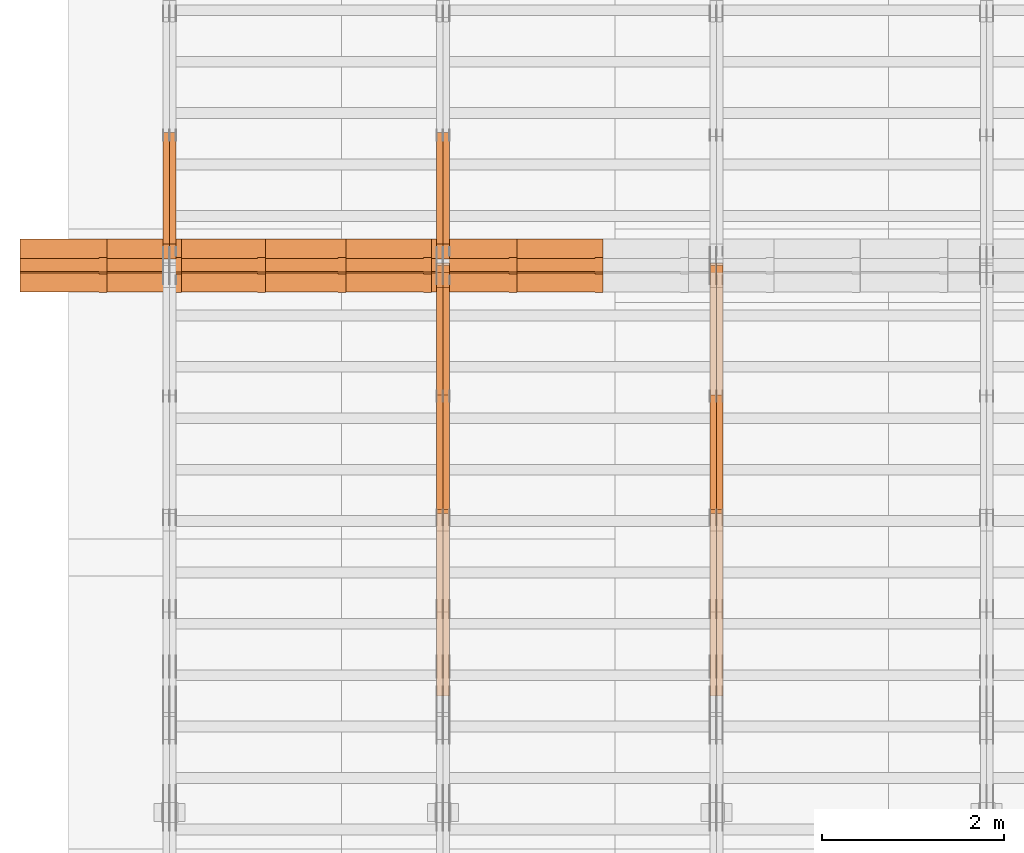
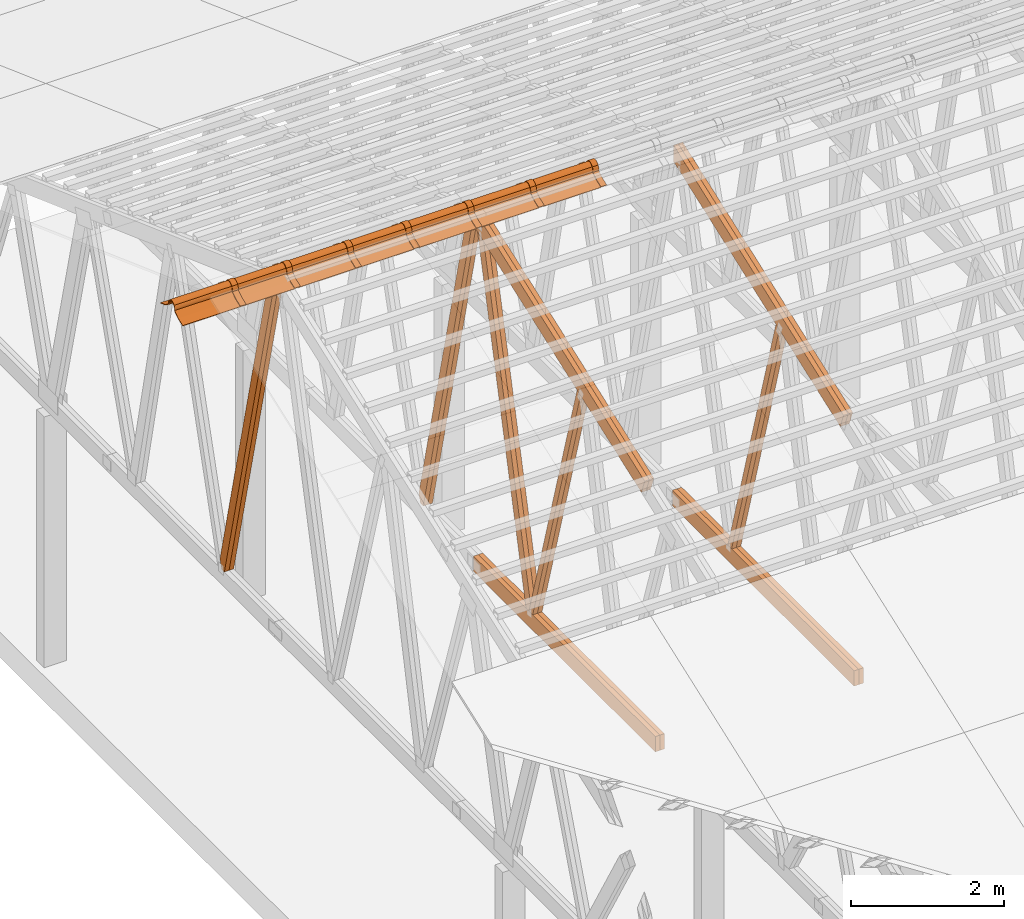
# One storey, part 17 of 189: 32 proxies.
"""IFC2X3 building model written with IfcOpenShell, lengths in millimetres."""

from ifc_helpers import new_model, entity, si_unit, converted_unit, derived_unit, direction, frame, frame_2d, origin, origin_2d_with_axis, place, context, subcontext, project, spatial, polyline, circle_curve, parameter, trimmed, segment, composite_curve, rectangle, outline, extrude, source, transform, mapped, material, type_object, type_shapes, element, save


model = new_model("IFC2X3")

# Units and contexts
model_context = context("Model", 3, precision=0.01, world=origin(), true_north=direction((6.12303176911189e-17, 1.0)))
body_context = subcontext(model_context, "Body", "Model", "MODEL_VIEW")
ifc_project = project(units=[si_unit("LENGTHUNIT", "METRE", prefix="MILLI"), si_unit("AREAUNIT", "SQUARE_METRE"), si_unit("VOLUMEUNIT", "CUBIC_METRE"), converted_unit("PLANEANGLEUNIT", "DEGREE", entity("IfcRatioMeasure", 0.0174532925199433), si_unit("PLANEANGLEUNIT", "RADIAN"), dimensions=[0, 0, 0, 0, 0, 0, 0]), si_unit("MASSUNIT", "GRAM", prefix="KILO"), derived_unit("MASSDENSITYUNIT", [(si_unit("MASSUNIT", "GRAM", prefix="KILO"), 1), (si_unit("LENGTHUNIT", "METRE"), -3)]), si_unit("TIMEUNIT", "SECOND"), si_unit("FREQUENCYUNIT", "HERTZ"), si_unit("THERMODYNAMICTEMPERATUREUNIT", "DEGREE_CELSIUS"), derived_unit("THERMALTRANSMITTANCEUNIT", [(si_unit("MASSUNIT", "GRAM", prefix="KILO"), 1), (si_unit("THERMODYNAMICTEMPERATUREUNIT", "KELVIN"), -1), (si_unit("TIMEUNIT", "SECOND"), -3)]), derived_unit("VOLUMETRICFLOWRATEUNIT", [(si_unit("LENGTHUNIT", "METRE"), 3), (si_unit("TIMEUNIT", "SECOND"), -1)]), si_unit("ELECTRICCURRENTUNIT", "AMPERE"), si_unit("ELECTRICVOLTAGEUNIT", "VOLT"), si_unit("POWERUNIT", "WATT"), si_unit("FORCEUNIT", "NEWTON"), si_unit("ILLUMINANCEUNIT", "LUX"), si_unit("LUMINOUSFLUXUNIT", "LUMEN"), si_unit("LUMINOUSINTENSITYUNIT", "CANDELA"), derived_unit("USERDEFINED", [(si_unit("MASSUNIT", "GRAM", prefix="KILO"), -1), (si_unit("LENGTHUNIT", "METRE"), -2), (si_unit("TIMEUNIT", "SECOND"), 3), (si_unit("LUMINOUSFLUXUNIT", "LUMEN"), 1)]), derived_unit("LINEARVELOCITYUNIT", [(si_unit("LENGTHUNIT", "METRE"), 1), (si_unit("TIMEUNIT", "SECOND"), -1)]), si_unit("PRESSUREUNIT", "PASCAL"), derived_unit("USERDEFINED", [(si_unit("LENGTHUNIT", "METRE"), -2), (si_unit("MASSUNIT", "GRAM", prefix="KILO"), 1), (si_unit("TIMEUNIT", "SECOND"), -2)])], contexts=[model_context])

# Site, building, storey
site_placement = place(None, origin())
site = spatial("IfcSite", under=ifc_project, at=site_placement, CompositionType="ELEMENT")
building_placement = place(site_placement, origin())
building = spatial("IfcBuilding", under=site, at=building_placement, CompositionType="ELEMENT")
storey_placement = place(building_placement, origin())
storey = spatial("IfcBuildingStorey", under=building, at=storey_placement, Name="Default", CompositionType="ELEMENT", Elevation=0.0)

# Proxies
ifc_material_1 = material(Name="IfcSurfaceStyle #36790")
building_element_proxy_type_1 = type_object("IfcBuildingElementProxyType", Name="T1-W6 36788", PredefinedType="NOTDEFINED", material=ifc_material_1)
shared_shape_1 = source(origin(), body_context, "Body", "SweptSolid", [
    extrude(outline(polyline([(-2640.84340836012, -47.4996765865792), (1711.12245024294, -47.4996765865792), (1797.68490303083, -9.57690019346202e-05), (1800.72595169379, 47.4997244710801), (-2668.68989660745, 47.4997244710801), (-2640.84340836012, -47.4996765865792)])), frame((1800.72595169379, 47.5003009358159, 0.0), z_axis=(0.0, 0.0, 1.0), x_axis=(-1.0, 0.0, 0.0)), (0.0, 0.0, 1.0), 69.9999999999997),
])
type_shapes(building_element_proxy_type_1, [shared_shape_1])
proxy_1_placement = place(building_placement, frame((6335.0, 12074.2896156894, 4533.9586582452), z_axis=(-1.0, 0.0, 0.0), x_axis=(0.0, 0.28128598310461, -0.959623986626467)))
element("IfcBuildingElementProxy", 1, at=proxy_1_placement, inside=storey, type_object=building_element_proxy_type_1, material=ifc_material_1, Name="T1-W6", context=body_context, shape_type="MappedRepresentation", body=[
    mapped(shared_shape_1, transform((0.0, 0.0, 0.0), scale=1.0)),
])
ifc_material_2 = material(Name="IfcSurfaceStyle #36724")
building_element_proxy_type_2 = type_object("IfcBuildingElementProxyType", Name="T1-W6 36722", PredefinedType="NOTDEFINED", material=ifc_material_2)
shared_shape_2 = source(origin(), body_context, "Body", "SweptSolid", [
    extrude(outline(polyline([(-2640.84340836012, -47.4996765865792), (1711.12245024294, -47.4996765865792), (1797.68490303083, -9.57690019346202e-05), (1800.72595169379, 47.4997244710801), (-2668.68989660745, 47.4997244710801), (-2640.84340836012, -47.4996765865792)])), frame((1800.72595169379, 47.5003009358159, 0.0), z_axis=(0.0, 0.0, 1.0), x_axis=(-1.0, 0.0, 0.0)), (0.0, 0.0, 1.0), 69.9999999999997),
])
type_shapes(building_element_proxy_type_2, [shared_shape_2])
proxy_2_placement = place(building_placement, frame((6265.0, 12074.2896156894, 4533.9586582452), z_axis=(-1.0, 0.0, 0.0), x_axis=(0.0, 0.28128598310461, -0.959623986626467)))
element("IfcBuildingElementProxy", 2, at=proxy_2_placement, inside=storey, type_object=building_element_proxy_type_2, material=ifc_material_2, Name="T1-W6", context=body_context, shape_type="MappedRepresentation", body=[
    mapped(shared_shape_2, transform((0.0, 0.0, 0.0), scale=1.0)),
])
ifc_material_3 = material(Name="IfcSurfaceStyle #32770")
building_element_proxy_type_3 = type_object("IfcBuildingElementProxyType", Name="T1-B3 32768", PredefinedType="NOTDEFINED", material=ifc_material_3)
shared_shape_3 = source(origin(), body_context, "Body", "SweptSolid", [
    extrude(rectangle(XDim=4751.0283203125, YDim=245.000000000001, at=origin_2d_with_axis()), frame((2375.51416015625, 122.5, 0.0), z_axis=(0.0, 0.0, 1.0), x_axis=(-1.0, 0.0, 0.0)), (0.0, 0.0, 1.0), 69.9999999999997),
])
type_shapes(building_element_proxy_type_3, [shared_shape_3])
proxy_3_placement = place(building_placement, frame((6335.0, 10029.23046875, 245.0), z_axis=(-1.0, 0.0, 0.0), x_axis=(0.0, 1.0, 0.0)))
element("IfcBuildingElementProxy", 3, at=proxy_3_placement, inside=storey, type_object=building_element_proxy_type_3, material=ifc_material_3, Name="T1-B3", context=body_context, shape_type="MappedRepresentation", body=[
    mapped(shared_shape_3, transform((0.0, 0.0, 0.0), scale=1.0)),
])
ifc_material_4 = material(Name="IfcSurfaceStyle #32713")
building_element_proxy_type_4 = type_object("IfcBuildingElementProxyType", Name="T1-B3 32711", PredefinedType="NOTDEFINED", material=ifc_material_4)
shared_shape_4 = source(origin(), body_context, "Body", "SweptSolid", [
    extrude(rectangle(XDim=4751.0283203125, YDim=245.000000000001, at=origin_2d_with_axis()), frame((2375.51416015625, 122.5, 0.0), z_axis=(0.0, 0.0, 1.0), x_axis=(-1.0, 0.0, 0.0)), (0.0, 0.0, 1.0), 69.9999999999997),
])
type_shapes(building_element_proxy_type_4, [shared_shape_4])
proxy_4_placement = place(building_placement, frame((6265.0, 10029.23046875, 245.0), z_axis=(-1.0, 0.0, 0.0), x_axis=(0.0, 1.0, 0.0)))
element("IfcBuildingElementProxy", 4, at=proxy_4_placement, inside=storey, type_object=building_element_proxy_type_4, material=ifc_material_4, Name="T1-B3", context=body_context, shape_type="MappedRepresentation", body=[
    mapped(shared_shape_4, transform((0.0, 0.0, 0.0), scale=1.0)),
])
ifc_material_5 = material(Name="IfcSurfaceStyle #32182")
building_element_proxy_type_5 = type_object("IfcBuildingElementProxyType", Name="T1-T3 32180", PredefinedType="NOTDEFINED", material=ifc_material_5)
shared_shape_5 = source(origin(), body_context, "Body", "SweptSolid", [
    extrude(outline(polyline([(-2341.64890001385, -122.499972785692), (2386.23525922045, -122.499972785692), (2297.06252495753, 122.499972785692), (-2341.64888416412, 122.499972785692), (-2341.64890001385, -122.499972785692)])), frame((2386.23525922045, 122.499973888764, 0.0), z_axis=(0.0, 0.0, 1.0), x_axis=(-1.0, 0.0, 0.0)), (0.0, 0.0, 1.0), 69.9999999999997),
])
type_shapes(building_element_proxy_type_5, [shared_shape_5])
proxy_5_placement = place(building_placement, frame((6335.0, 14833.7949607394, 5538.33627266055), z_axis=(-1.0, 0.0, 0.0), x_axis=(0.0, -0.939692620785908, -0.342020143325669)))
element("IfcBuildingElementProxy", 5, at=proxy_5_placement, inside=storey, type_object=building_element_proxy_type_5, material=ifc_material_5, Name="T1-T3", context=body_context, shape_type="MappedRepresentation", body=[
    mapped(shared_shape_5, transform((0.0, 0.0, 0.0), scale=1.0)),
])
ifc_material_6 = material(Name="IfcSurfaceStyle #32125")
building_element_proxy_type_6 = type_object("IfcBuildingElementProxyType", Name="T1-T3 32123", PredefinedType="NOTDEFINED", material=ifc_material_6)
shared_shape_6 = source(origin(), body_context, "Body", "SweptSolid", [
    extrude(outline(polyline([(-2341.64890001385, -122.499972785692), (2386.23525922045, -122.499972785692), (2297.06252495753, 122.499972785692), (-2341.64888416412, 122.499972785692), (-2341.64890001385, -122.499972785692)])), frame((2386.23525922045, 122.499973888764, 0.0), z_axis=(0.0, 0.0, 1.0), x_axis=(-1.0, 0.0, 0.0)), (0.0, 0.0, 1.0), 69.9999999999997),
])
type_shapes(building_element_proxy_type_6, [shared_shape_6])
proxy_6_placement = place(building_placement, frame((6265.0, 14833.7949607394, 5538.33627266055), z_axis=(-1.0, 0.0, 0.0), x_axis=(0.0, -0.939692620785908, -0.342020143325669)))
element("IfcBuildingElementProxy", 6, at=proxy_6_placement, inside=storey, type_object=building_element_proxy_type_6, material=ifc_material_6, Name="T1-T3", context=body_context, shape_type="MappedRepresentation", body=[
    mapped(shared_shape_6, transform((0.0, 0.0, 0.0), scale=1.0)),
])
ifc_material_7 = material(Name="IfcSurfaceStyle #21264")
building_element_proxy_type_7 = type_object("IfcBuildingElementProxyType", Name="T1-W5 21262", PredefinedType="NOTDEFINED", material=ifc_material_7)
shared_shape_7 = source(origin(), body_context, "Body", "SweptSolid", [
    extrude(outline(polyline([(-3233.61216530572, -72.4999091305202), (2153.79187521892, -72.4999091305202), (2171.36968478227, -7.18521572819375e-05), (2045.62106208646, 72.4999450565989), (-3137.17045678193, 72.4999450565989), (-3233.61216530572, -72.4999091305202)])), frame((2171.36968478227, 72.500192121173, 0.0), z_axis=(0.0, 0.0, 1.0), x_axis=(-1.0, 0.0, 0.0)), (0.0, 0.0, 1.0), 69.9999999999997),
])
type_shapes(building_element_proxy_type_7, [shared_shape_7])
proxy_7_placement = place(building_placement, frame((3335.0, 13261.0146935344, 262.082919891325), z_axis=(-1.0, 0.0, 0.0), x_axis=(0.0, 0.235625623344066, 0.97184389982328)))
element("IfcBuildingElementProxy", 7, at=proxy_7_placement, inside=storey, type_object=building_element_proxy_type_7, material=ifc_material_7, Name="T1-W5", context=body_context, shape_type="MappedRepresentation", body=[
    mapped(shared_shape_7, transform((0.0, 0.0, 0.0), scale=1.0)),
])
ifc_material_8 = material(Name="IfcSurfaceStyle #21198")
building_element_proxy_type_8 = type_object("IfcBuildingElementProxyType", Name="T1-W5 21196", PredefinedType="NOTDEFINED", material=ifc_material_8)
shared_shape_8 = source(origin(), body_context, "Body", "SweptSolid", [
    extrude(outline(polyline([(-3233.61216530572, -72.4999091305202), (2153.79187521892, -72.4999091305202), (2171.36968478227, -7.18521572819375e-05), (2045.62106208646, 72.4999450565989), (-3137.17045678193, 72.4999450565989), (-3233.61216530572, -72.4999091305202)])), frame((2171.36968478227, 72.500192121173, 0.0), z_axis=(0.0, 0.0, 1.0), x_axis=(-1.0, 0.0, 0.0)), (0.0, 0.0, 1.0), 69.9999999999997),
])
type_shapes(building_element_proxy_type_8, [shared_shape_8])
proxy_8_placement = place(building_placement, frame((3265.0, 13261.0146935344, 262.082919891325), z_axis=(-1.0, 0.0, 0.0), x_axis=(0.0, 0.235625623344066, 0.97184389982328)))
element("IfcBuildingElementProxy", 8, at=proxy_8_placement, inside=storey, type_object=building_element_proxy_type_8, material=ifc_material_8, Name="T1-W5", context=body_context, shape_type="MappedRepresentation", body=[
    mapped(shared_shape_8, transform((0.0, 0.0, 0.0), scale=1.0)),
])
ifc_material_9 = material(Name="IfcSurfaceStyle #21132")
building_element_proxy_type_9 = type_object("IfcBuildingElementProxyType", Name="T1-W5 21130", PredefinedType="NOTDEFINED", material=ifc_material_9)
shared_shape_9 = source(origin(), body_context, "Body", "SweptSolid", [
    extrude(outline(polyline([(-3137.17045678193, -72.5002081306407), (2045.62106208646, -72.5002081306408), (2171.36968478227, 5.58426931168476e-05), (2153.79187521892, 72.5001802092942), (-3233.61216530572, 72.5001802092942), (-3137.17045678193, -72.5002081306407)])), frame((2171.36968478227, 72.5001802092942, 0.0), z_axis=(0.0, 0.0, 1.0), x_axis=(-1.0, 0.0, 0.0)), (0.0, 0.0, 1.0), 69.9999999999997),
])
type_shapes(building_element_proxy_type_9, [shared_shape_9])
proxy_9_placement = place(building_placement, frame((3335.0, 16098.0675635854, 227.917113003597), z_axis=(-1.0, 0.0, 0.0), x_axis=(0.0, -0.235625623344066, 0.971843899823279)))
element("IfcBuildingElementProxy", 9, at=proxy_9_placement, inside=storey, type_object=building_element_proxy_type_9, material=ifc_material_9, Name="T1-W5", context=body_context, shape_type="MappedRepresentation", body=[
    mapped(shared_shape_9, transform((0.0, 0.0, 0.0), scale=1.0)),
])
ifc_material_10 = material(Name="IfcSurfaceStyle #21066")
building_element_proxy_type_10 = type_object("IfcBuildingElementProxyType", Name="T1-W5 21064", PredefinedType="NOTDEFINED", material=ifc_material_10)
shared_shape_10 = source(origin(), body_context, "Body", "SweptSolid", [
    extrude(outline(polyline([(-3137.17045678193, -72.5002081306407), (2045.62106208646, -72.5002081306408), (2171.36968478227, 5.58426931168476e-05), (2153.79187521892, 72.5001802092942), (-3233.61216530572, 72.5001802092942), (-3137.17045678193, -72.5002081306407)])), frame((2171.36968478227, 72.5001802092942, 0.0), z_axis=(0.0, 0.0, 1.0), x_axis=(-1.0, 0.0, 0.0)), (0.0, 0.0, 1.0), 69.9999999999997),
])
type_shapes(building_element_proxy_type_10, [shared_shape_10])
proxy_10_placement = place(building_placement, frame((3265.0, 16098.0675635854, 227.917113003597), z_axis=(-1.0, 0.0, 0.0), x_axis=(0.0, -0.235625623344066, 0.971843899823279)))
element("IfcBuildingElementProxy", 10, at=proxy_10_placement, inside=storey, type_object=building_element_proxy_type_10, material=ifc_material_10, Name="T1-W5", context=body_context, shape_type="MappedRepresentation", body=[
    mapped(shared_shape_10, transform((0.0, 0.0, 0.0), scale=1.0)),
])
ifc_material_11 = material(Name="IfcSurfaceStyle #21000")
building_element_proxy_type_11 = type_object("IfcBuildingElementProxyType", Name="T1-W6 20998", PredefinedType="NOTDEFINED", material=ifc_material_11)
shared_shape_11 = source(origin(), body_context, "Body", "SweptSolid", [
    extrude(outline(polyline([(-2640.84340836012, -47.4996765865792), (1711.12245024294, -47.4996765865792), (1797.68490303083, -9.57690019346202e-05), (1800.72595169379, 47.4997244710801), (-2668.68989660745, 47.4997244710801), (-2640.84340836012, -47.4996765865792)])), frame((1800.72595169379, 47.5003009358159, 0.0), z_axis=(0.0, 0.0, 1.0), x_axis=(-1.0, 0.0, 0.0)), (0.0, 0.0, 1.0), 69.9999999999997),
])
type_shapes(building_element_proxy_type_11, [shared_shape_11])
proxy_11_placement = place(building_placement, frame((3335.0, 12074.2896156894, 4533.9586582452), z_axis=(-1.0, 0.0, 0.0), x_axis=(0.0, 0.28128598310461, -0.959623986626467)))
element("IfcBuildingElementProxy", 11, at=proxy_11_placement, inside=storey, type_object=building_element_proxy_type_11, material=ifc_material_11, Name="T1-W6", context=body_context, shape_type="MappedRepresentation", body=[
    mapped(shared_shape_11, transform((0.0, 0.0, 0.0), scale=1.0)),
])
ifc_material_12 = material(Name="IfcSurfaceStyle #20934")
building_element_proxy_type_12 = type_object("IfcBuildingElementProxyType", Name="T1-W6 20932", PredefinedType="NOTDEFINED", material=ifc_material_12)
shared_shape_12 = source(origin(), body_context, "Body", "SweptSolid", [
    extrude(outline(polyline([(-2640.84340836012, -47.4996765865792), (1711.12245024294, -47.4996765865792), (1797.68490303083, -9.57690019346202e-05), (1800.72595169379, 47.4997244710801), (-2668.68989660745, 47.4997244710801), (-2640.84340836012, -47.4996765865792)])), frame((1800.72595169379, 47.5003009358159, 0.0), z_axis=(0.0, 0.0, 1.0), x_axis=(-1.0, 0.0, 0.0)), (0.0, 0.0, 1.0), 69.9999999999997),
])
type_shapes(building_element_proxy_type_12, [shared_shape_12])
proxy_12_placement = place(building_placement, frame((3265.0, 12074.2896156894, 4533.9586582452), z_axis=(-1.0, 0.0, 0.0), x_axis=(0.0, 0.28128598310461, -0.959623986626467)))
element("IfcBuildingElementProxy", 12, at=proxy_12_placement, inside=storey, type_object=building_element_proxy_type_12, material=ifc_material_12, Name="T1-W6", context=body_context, shape_type="MappedRepresentation", body=[
    mapped(shared_shape_12, transform((0.0, 0.0, 0.0), scale=1.0)),
])
ifc_material_13 = material(Name="IfcSurfaceStyle #16980")
building_element_proxy_type_13 = type_object("IfcBuildingElementProxyType", Name="T1-B3 16978", PredefinedType="NOTDEFINED", material=ifc_material_13)
shared_shape_13 = source(origin(), body_context, "Body", "SweptSolid", [
    extrude(rectangle(XDim=4751.0283203125, YDim=245.000000000001, at=origin_2d_with_axis()), frame((2375.51416015625, 122.5, 0.0), z_axis=(0.0, 0.0, 1.0), x_axis=(-1.0, 0.0, 0.0)), (0.0, 0.0, 1.0), 69.9999999999997),
])
type_shapes(building_element_proxy_type_13, [shared_shape_13])
proxy_13_placement = place(building_placement, frame((3335.0, 10029.23046875, 245.0), z_axis=(-1.0, 0.0, 0.0), x_axis=(0.0, 1.0, 0.0)))
element("IfcBuildingElementProxy", 13, at=proxy_13_placement, inside=storey, type_object=building_element_proxy_type_13, material=ifc_material_13, Name="T1-B3", context=body_context, shape_type="MappedRepresentation", body=[
    mapped(shared_shape_13, transform((0.0, 0.0, 0.0), scale=1.0)),
])
ifc_material_14 = material(Name="IfcSurfaceStyle #16923")
building_element_proxy_type_14 = type_object("IfcBuildingElementProxyType", Name="T1-B3 16921", PredefinedType="NOTDEFINED", material=ifc_material_14)
shared_shape_14 = source(origin(), body_context, "Body", "SweptSolid", [
    extrude(rectangle(XDim=4751.0283203125, YDim=245.000000000001, at=origin_2d_with_axis()), frame((2375.51416015625, 122.5, 0.0), z_axis=(0.0, 0.0, 1.0), x_axis=(-1.0, 0.0, 0.0)), (0.0, 0.0, 1.0), 69.9999999999997),
])
type_shapes(building_element_proxy_type_14, [shared_shape_14])
proxy_14_placement = place(building_placement, frame((3265.0, 10029.23046875, 245.0), z_axis=(-1.0, 0.0, 0.0), x_axis=(0.0, 1.0, 0.0)))
element("IfcBuildingElementProxy", 14, at=proxy_14_placement, inside=storey, type_object=building_element_proxy_type_14, material=ifc_material_14, Name="T1-B3", context=body_context, shape_type="MappedRepresentation", body=[
    mapped(shared_shape_14, transform((0.0, 0.0, 0.0), scale=1.0)),
])
ifc_material_15 = material(Name="IfcSurfaceStyle #16392")
building_element_proxy_type_15 = type_object("IfcBuildingElementProxyType", Name="T1-T3 16390", PredefinedType="NOTDEFINED", material=ifc_material_15)
shared_shape_15 = source(origin(), body_context, "Body", "SweptSolid", [
    extrude(outline(polyline([(-2341.64890001385, -122.499972785692), (2386.23525922045, -122.499972785692), (2297.06252495753, 122.499972785692), (-2341.64888416412, 122.499972785692), (-2341.64890001385, -122.499972785692)])), frame((2386.23525922045, 122.499973888764, 0.0), z_axis=(0.0, 0.0, 1.0), x_axis=(-1.0, 0.0, 0.0)), (0.0, 0.0, 1.0), 69.9999999999997),
])
type_shapes(building_element_proxy_type_15, [shared_shape_15])
proxy_15_placement = place(building_placement, frame((3335.0, 14833.7949607394, 5538.33627266055), z_axis=(-1.0, 0.0, 0.0), x_axis=(0.0, -0.939692620785908, -0.342020143325669)))
element("IfcBuildingElementProxy", 15, at=proxy_15_placement, inside=storey, type_object=building_element_proxy_type_15, material=ifc_material_15, Name="T1-T3", context=body_context, shape_type="MappedRepresentation", body=[
    mapped(shared_shape_15, transform((0.0, 0.0, 0.0), scale=1.0)),
])
ifc_material_16 = material(Name="IfcSurfaceStyle #16335")
building_element_proxy_type_16 = type_object("IfcBuildingElementProxyType", Name="T1-T3 16333", PredefinedType="NOTDEFINED", material=ifc_material_16)
shared_shape_16 = source(origin(), body_context, "Body", "SweptSolid", [
    extrude(outline(polyline([(-2341.64890001385, -122.499972785692), (2386.23525922045, -122.499972785692), (2297.06252495753, 122.499972785692), (-2341.64888416412, 122.499972785692), (-2341.64890001385, -122.499972785692)])), frame((2386.23525922045, 122.499973888764, 0.0), z_axis=(0.0, 0.0, 1.0), x_axis=(-1.0, 0.0, 0.0)), (0.0, 0.0, 1.0), 69.9999999999997),
])
type_shapes(building_element_proxy_type_16, [shared_shape_16])
proxy_16_placement = place(building_placement, frame((3265.0, 14833.7949607394, 5538.33627266055), z_axis=(-1.0, 0.0, 0.0), x_axis=(0.0, -0.939692620785908, -0.342020143325669)))
element("IfcBuildingElementProxy", 16, at=proxy_16_placement, inside=storey, type_object=building_element_proxy_type_16, material=ifc_material_16, Name="T1-T3", context=body_context, shape_type="MappedRepresentation", body=[
    mapped(shared_shape_16, transform((0.0, 0.0, 0.0), scale=1.0)),
])
ifc_material_17 = material(Name="IfcSurfaceStyle #5339")
building_element_proxy_type_17 = type_object("IfcBuildingElementProxyType", Name="T1-W5 5337", PredefinedType="NOTDEFINED", material=ifc_material_17)
shared_shape_17 = source(origin(), body_context, "Body", "SweptSolid", [
    extrude(outline(polyline([(-3137.17045678193, -72.5002081306407), (2045.62106208646, -72.5002081306408), (2171.36968478227, 5.58426931168476e-05), (2153.79187521892, 72.5001802092942), (-3233.61216530572, 72.5001802092942), (-3137.17045678193, -72.5002081306407)])), frame((2171.36968478227, 72.5001802092942, 0.0), z_axis=(0.0, 0.0, 1.0), x_axis=(-1.0, 0.0, 0.0)), (0.0, 0.0, 1.0), 69.9999999999997),
])
type_shapes(building_element_proxy_type_17, [shared_shape_17])
proxy_17_placement = place(building_placement, frame((335.0, 16098.0675635854, 227.917113003597), z_axis=(-1.0, 0.0, 0.0), x_axis=(0.0, -0.235625623344066, 0.971843899823279)))
element("IfcBuildingElementProxy", 17, at=proxy_17_placement, inside=storey, type_object=building_element_proxy_type_17, material=ifc_material_17, Name="T1-W5", context=body_context, shape_type="MappedRepresentation", body=[
    mapped(shared_shape_17, transform((0.0, 0.0, 0.0), scale=1.0)),
])
ifc_material_18 = material(Name="IfcSurfaceStyle #5273")
building_element_proxy_type_18 = type_object("IfcBuildingElementProxyType", Name="T1-W5 5271", PredefinedType="NOTDEFINED", material=ifc_material_18)
shared_shape_18 = source(origin(), body_context, "Body", "SweptSolid", [
    extrude(outline(polyline([(-3137.17045678193, -72.5002081306407), (2045.62106208646, -72.5002081306408), (2171.36968478227, 5.58426931168476e-05), (2153.79187521892, 72.5001802092942), (-3233.61216530572, 72.5001802092942), (-3137.17045678193, -72.5002081306407)])), frame((2171.36968478227, 72.5001802092942, 0.0), z_axis=(0.0, 0.0, 1.0), x_axis=(-1.0, 0.0, 0.0)), (0.0, 0.0, 1.0), 69.9999999999997),
])
type_shapes(building_element_proxy_type_18, [shared_shape_18])
proxy_18_placement = place(building_placement, frame((265.0, 16098.0675635854, 227.917113003597), z_axis=(-1.0, 0.0, 0.0), x_axis=(0.0, -0.235625623344066, 0.971843899823279)))
element("IfcBuildingElementProxy", 18, at=proxy_18_placement, inside=storey, type_object=building_element_proxy_type_18, material=ifc_material_18, Name="T1-W5", context=body_context, shape_type="MappedRepresentation", body=[
    mapped(shared_shape_18, transform((0.0, 0.0, 0.0), scale=1.0)),
])
ifc_material_19 = material()
building_element_proxy_type_19 = type_object("IfcBuildingElementProxyType", Name="P75", PredefinedType="NOTDEFINED", material=ifc_material_19)
shared_shape_19 = source(origin(), body_context, "Body", "SweptSolid", [
    extrude(outline(composite_curve([segment(polyline([(-69.4623915065845, -4.60763114971976), (47.4521071665907, -4.60763114971981)]), True, "CONTINUOUS"), segment(trimmed(circle_curve(frame_2d((119.940978060963, 14.6372018310859), x_axis=(-0.966518278591622, -0.256597773077395)), 75.0), [parameter(6.61555373744412e-13)], [parameter(180.0)], True, "PARAMETER"), True, "CONTINUOUS"), segment(polyline([(192.429848955335, 33.882034811891), (182.764666169419, 31.3160570811166)]), True, "CONTINUOUS"), segment(trimmed(circle_curve(frame_2d((119.940978060963, 14.6372018310859), x_axis=(-0.966518278591622, -0.256597773077395)), 65.0), [parameter(1.06866637297174e-12)], [parameter(180.0)], True, "PARAMETER"), False, "CONTINUOUS"), segment(polyline([(57.1172899525073, -2.04165341894578), (47.4521071665911, 5.39236885028051)]), True, "CONTINUOUS"), segment(polyline([(47.4521071665911, 5.39236885028052), (-70.7672243976422, 5.39236885028094)]), True, "CONTINUOUS"), segment(polyline([(-70.7672243976422, 5.39236885028094), (-194.776190618495, -27.5303655446341)]), True, "CONTINUOUS"), segment(polyline([(-194.776190618495, -27.5303655446341), (-192.210212887721, -37.1955483305503)]), True, "CONTINUOUS"), segment(polyline([(-192.210212887721, -37.1955483305503), (-69.4623915065845, -4.60763114971974)]), True, "CONTINUOUS")], self_intersect=False)), frame((0.0, 106.775760402721, -56.5599052870917), z_axis=(1.0, 0.0, 0.0), x_axis=(0.0, -0.820468487122275, 0.571691754041709)), (0.0, 0.0, 1.0), 867.000000000001),
    extrude(outline(composite_curve([segment(polyline([(62.2906866429439, -18.428943356533), (189.290686642944, -18.428943356533)]), True, "CONTINUOUS"), segment(polyline([(189.290686642944, -18.428943356533), (189.290686642944, -8.42894335653292)]), True, "CONTINUOUS"), segment(polyline([(189.290686642944, -8.42894335653292), (62.2906866429439, -8.42894335653294)]), True, "CONTINUOUS"), segment(polyline([(62.2906866429439, -8.42894335653294), (-41.0348065006093, 19.0026034957362)]), True, "CONTINUOUS"), segment(trimmed(circle_curve(frame_2d((-125.709313357056, 11.5710566434651), x_axis=(1.0, 0.0)), 85.0), [parameter(5.01577186738723)], [parameter(180.0)], True, "PARAMETER"), True, "CONTINUOUS"), segment(polyline([(-210.709313357056, 11.5710566434656), (-200.709313357056, 11.5710566434656)]), True, "CONTINUOUS"), segment(trimmed(circle_curve(frame_2d((-125.709313357056, 11.5710566434651), x_axis=(1.0, 0.0)), 75.0), [parameter(3.05333249420498e-13)], [parameter(180.0)], True, "PARAMETER"), False, "CONTINUOUS"), segment(polyline([(-50.7093133570542, 11.5710566434655), (62.290686642944, -18.4289433565322)]), True, "CONTINUOUS")], self_intersect=False)), frame((867.0, 114.170579674061, -53.8683539143053), z_axis=(1.0, 0.0, 0.0), x_axis=(0.0, 0.939692620785914, -0.342020143325653)), (0.0, 0.0, 1.0), 86.9999999999998),
])
type_shapes(building_element_proxy_type_19, [shared_shape_19])
for number, where, name in (
    (19, (4063.91649737545, 14755.0000438632, 5865.69618295448), "P75, generic model20:P75"),
    (20, (3123.91649737545, 14755.0000438632, 5865.69618295448), "P75, generic model20:P75"),
    (21, (2183.91649737545, 14755.0000438632, 5865.69618295448), "P75, generic model20:P75"),
    (22, (1243.91649737545, 14755.0000438632, 5865.69618295448), "P75, generic model20:P75"),
    (23, (363.916497375451, 14755.0000438632, 5865.69618295448), "P75, generic model20:P75"),
    (24, (-556.083502624549, 14755.0000438632, 5865.69618295448), "P75, generic model20:P75"),
    (25, (-1376.08350262455, 14755.0000438632, 5865.69618295448), "P75, generic model20:P75"),
):
    element("IfcBuildingElementProxy", number, at=place(storey_placement, frame(where)), inside=storey, type_object=building_element_proxy_type_19, material=ifc_material_19, Name=name, ObjectType="P75, generic model20:P75", context=body_context, shape_type="MappedRepresentation", body=[
        mapped(shared_shape_19, transform((0.0, 0.0, 0.0), scale=1.0)),
    ])
building_element_proxy_type_20 = type_object("IfcBuildingElementProxyType", Name="P75", PredefinedType="NOTDEFINED", material=ifc_material_19)
shared_shape_20 = source(origin(), body_context, "Body", "SweptSolid", [
    extrude(outline(composite_curve([segment(polyline([(68.3189789579817, 13.3705352460084), (195.318978957982, 13.3705352460084)]), True, "CONTINUOUS"), segment(polyline([(195.318978957982, 13.3705352460084), (195.318978957982, 23.3705352460084)]), True, "CONTINUOUS"), segment(polyline([(195.318978957982, 23.3705352460084), (67.014146066922, 23.3705352460088)]), True, "CONTINUOUS"), segment(polyline([(67.014146066922, 23.3705352460088), (-47.2469987727929, -6.96428196807339)]), True, "CONTINUOUS"), segment(polyline([(-47.2469987727929, -6.96428196807339), (-54.6810210420187, -16.62946475399)]), True, "CONTINUOUS"), segment(trimmed(circle_curve(frame_2d((-119.681021042019, -16.6294647539896), x_axis=(1.0, 0.0)), 65.0), [parameter(180.0)], [parameter(359.999999999999)], True, "PARAMETER"), False, "CONTINUOUS"), segment(polyline([(-184.681021042019, -16.6294647539905), (-194.681021042019, -16.6294647539901)]), True, "CONTINUOUS"), segment(trimmed(circle_curve(frame_2d((-119.681021042019, -16.6294647539896), x_axis=(1.0, 0.0)), 75.0), [parameter(180.0)], [parameter(359.999999999999)], True, "PARAMETER"), True, "CONTINUOUS"), segment(polyline([(-44.6810210420183, -16.6294647539898), (68.3189789579816, 13.3705352460083)]), True, "CONTINUOUS")], self_intersect=False)), frame((0.0, -106.775760402721, -56.5599052870916), z_axis=(1.0, 0.0, 0.0), x_axis=(0.0, -0.939692620785914, -0.342020143325654)), (0.0, 0.0, 1.0), 867.000000000001),
    extrude(outline(composite_curve([segment(polyline([(-64.9339130518847, 1.82825913317695), (-187.681734433021, -30.7596580476538)]), True, "CONTINUOUS"), segment(polyline([(-187.681734433021, -30.7596580476538), (-185.115756702247, -40.4248408335702)]), True, "CONTINUOUS"), segment(polyline([(-185.115756702247, -40.4248408335702), (-62.3679353211107, -7.83692365273935)]), True, "CONTINUOUS"), segment(polyline([(-62.3679353211107, -7.83692365273935), (44.5369162809878, -7.83692365273935)]), True, "CONTINUOUS"), segment(trimmed(circle_curve(frame_2d((124.469456515662, 21.0730921139827), x_axis=(-0.966518278591636, -0.256597773077402)), 85.0), [parameter(5.01577186738723)], [parameter(180.0)], True, "PARAMETER"), True, "CONTINUOUS"), segment(polyline([(206.623510195951, 42.8839028255618), (196.958327410034, 40.3179250947878)]), True, "CONTINUOUS"), segment(trimmed(circle_curve(frame_2d((124.469456515662, 21.0730921139827), x_axis=(-0.966518278591636, -0.256597773077402)), 75.0), [parameter(3.05333249420498e-13)], [parameter(180.0)], True, "PARAMETER"), False, "CONTINUOUS"), segment(polyline([(51.9805856212887, 1.82825913317622), (-64.9339130518846, 1.82825913317621)]), True, "CONTINUOUS")], self_intersect=False)), frame((867.0, -114.170579674061, -53.868353914305), z_axis=(-1.0, 0.0, 0.0), x_axis=(0.0, 0.820468487122275, 0.571691754041709)), (0.0, 0.0, -1.0), 86.9999999999998),
])
type_shapes(building_element_proxy_type_20, [shared_shape_20])
for number, where, name in (
    (26, (4063.91649737545, 14745.0000384614, 5850.69618295448), "P75, generic model20:P75"),
    (27, (3123.91649737545, 14745.0000384614, 5850.69618295448), "P75, generic model20:P75"),
    (28, (2183.91649737545, 14745.0000384614, 5850.69618295448), "P75, generic model20:P75"),
    (29, (1243.91649737545, 14745.0000384614, 5850.69618295448), "P75, generic model20:P75"),
    (30, (363.916497375451, 14745.0000384614, 5850.69618295448), "P75, generic model20:P75"),
    (31, (-556.083502624549, 14745.0000384614, 5850.69618295448), "P75, generic model20:P75"),
    (32, (-1376.08350262455, 14745.0000384614, 5850.69618295448), "P75, generic model20:P75"),
):
    element("IfcBuildingElementProxy", number, at=place(storey_placement, frame(where)), inside=storey, type_object=building_element_proxy_type_20, material=ifc_material_19, Name=name, ObjectType="P75, generic model20:P75", context=body_context, shape_type="MappedRepresentation", body=[
        mapped(shared_shape_20, transform((0.0, 0.0, 0.0), scale=1.0)),
    ])

save(model, "model.ifc")
